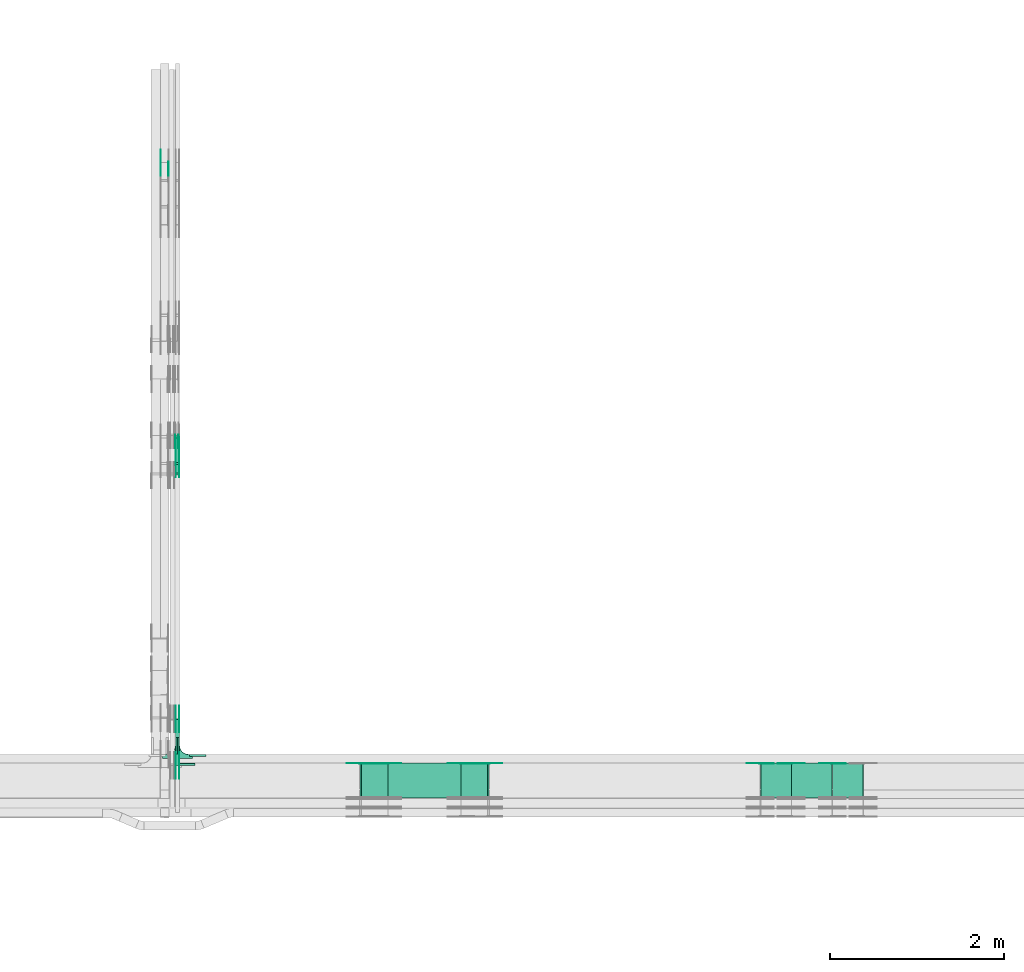
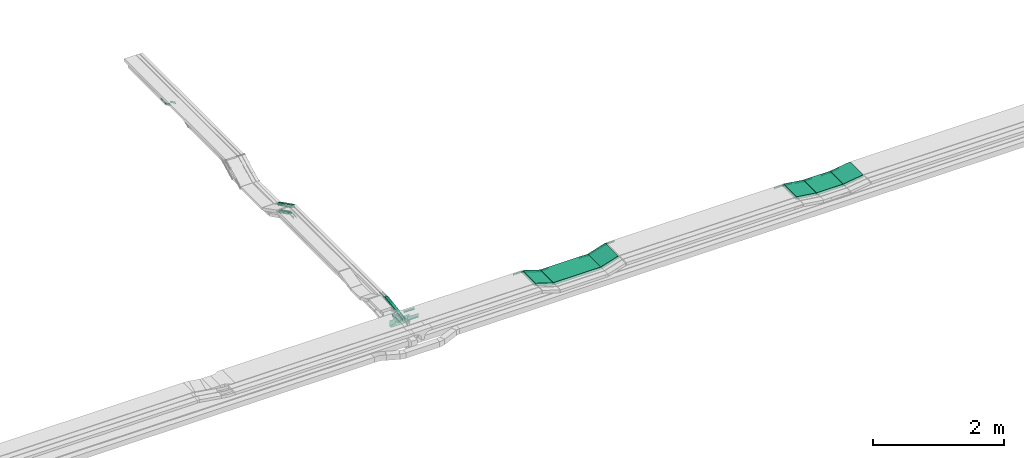
# One storey, part 19 of 28: 38 flow fittings, 9 flow segments.
"""IFC2X3 building model written with IfcOpenShell, lengths in millimetres."""

import ifcopenshell
import ifcopenshell.guid

model = None  # the IFC model being written
_history = None  # IfcOwnerHistory: only IFC2X3 demands one
_inside = {}  # id of a spatial element -> (the spatial element, [elements in it])
_under = {}  # id of a project, library or spatial element -> (it, [spatial elements below it])
_declared = {}  # id of a project -> (the project, [libraries it declares])
_typed = {}  # id of a type object -> (the type object, [elements of that type])
_made_of = {}  # id of a material, layer set ... -> (it, [elements and type objects made of it])


def new_model(schema):
    """Start an empty IFC model of exactly this schema.

    Asked for "IFC4X3", IfcOpenShell would pick the latest addendum, in which some entities
    have other attributes; the version numbers below select the first issue.
    IFC2X3 requires an IfcOwnerHistory on every rooted entity: one is made here for all.
    """
    global model, _history
    if schema == "IFC4X3":
        model = ifcopenshell.file(schema_version=(4, 3, 0, 0))
    else:
        model = ifcopenshell.file(schema=schema)
    _inside.clear()
    _under.clear()
    _declared.clear()
    _typed.clear()
    _made_of.clear()
    _history = None
    if model.schema == "IFC2X3":
        org = make("IfcOrganization", Name="unknown")
        user = make(
            "IfcPersonAndOrganization",
            ThePerson=make("IfcPerson", FamilyName="unknown"),
            TheOrganization=org,
        )
        app = make(
            "IfcApplication",
            ApplicationDeveloper=org,
            Version="unknown",
            ApplicationFullName="unknown",
            ApplicationIdentifier="unknown",
        )
        _history = make(
            "IfcOwnerHistory",
            OwningUser=user,
            OwningApplication=app,
            ChangeAction="ADDED",
            CreationDate=0,
        )
    return model


def make(cls, **values):
    """One entity of the class cls with the attributes given. An attribute that is None is left unset."""
    return model.create_entity(
        cls, **{name: value for name, value in values.items() if value is not None}
    )


def entity(cls, *values):
    """Any entity or typed value of the class cls, its attributes in the order of the schema. None: left unset."""
    e = model.create_entity(cls)
    for i, value in enumerate(values):
        if value is not None:
            e[i] = value
    return e


def rooted(cls, **values):
    """An entity with a GlobalId (a new one), such as an element, a storey or a relation."""
    return make(cls, GlobalId=ifcopenshell.guid.new(), OwnerHistory=_history, **values)


def si_unit(unit_type, name, prefix=None):
    """IfcSIUnit, for example si_unit("LENGTHUNIT", "METRE", prefix="MILLI")."""
    return make("IfcSIUnit", UnitType=unit_type, Prefix=prefix, Name=name)


def converted_unit(unit_type, name, factor, base, dimensions=None, offset=None):
    """IfcConversionBasedUnit, such as the inch: factor (a typed value) times the base unit."""
    return make(
        "IfcConversionBasedUnit"
        if offset is None
        else "IfcConversionBasedUnitWithOffset",
        ConversionOffset=offset,
        Dimensions=None
        if dimensions is None
        else entity("IfcDimensionalExponents", *dimensions),
        UnitType=unit_type,
        Name=name,
        ConversionFactor=make(
            "IfcMeasureWithUnit", ValueComponent=factor, UnitComponent=base
        ),
    )


def derived_unit(unit_type, elements):
    """IfcDerivedUnit: a product of units, each with its exponent."""
    return make(
        "IfcDerivedUnit",
        Elements=[
            make("IfcDerivedUnitElement", Unit=unit, Exponent=power)
            for unit, power in elements
        ],
        UnitType=unit_type,
    )


def assignment(units):
    """IfcUnitAssignment: the units of a project."""
    return None if units is None else make("IfcUnitAssignment", Units=units)


def point(xyz):
    """IfcCartesianPoint."""
    return None if xyz is None else make("IfcCartesianPoint", Coordinates=xyz)


def direction(xyz):
    """IfcDirection."""
    return None if xyz is None else make("IfcDirection", DirectionRatios=xyz)


def frame(location, z_axis=None, x_axis=None):
    """IfcAxis2Placement3D, a coordinate frame: its origin and axes. An axis left out is left unset."""
    return make(
        "IfcAxis2Placement3D",
        Location=point(location),
        Axis=direction(z_axis),
        RefDirection=direction(x_axis),
    )


def frame_2d(location, x_axis=None):
    """IfcAxis2Placement2D, a coordinate frame in the plane: its origin and x axis."""
    return make(
        "IfcAxis2Placement2D", Location=point(location), RefDirection=direction(x_axis)
    )


def origin():
    """The frame at (0, 0, 0) with its axes left unset."""
    return frame((0.0, 0.0, 0.0))


def place(relative_to, where):
    """IfcLocalPlacement: puts the frame where relative to a parent placement (None: the world)."""
    return make(
        "IfcLocalPlacement", PlacementRelTo=relative_to, RelativePlacement=where
    )


def context(
    kind, dimensions, precision=None, world=None, true_north=None, identifier=None
):
    """IfcGeometricRepresentationContext, for example the 3D "Model" context."""
    return make(
        "IfcGeometricRepresentationContext",
        ContextIdentifier=identifier,
        ContextType=kind,
        CoordinateSpaceDimension=dimensions,
        Precision=precision,
        WorldCoordinateSystem=world,
        TrueNorth=true_north,
    )


def subcontext(parent, identifier, kind, view, scale=None):
    """IfcGeometricRepresentationSubContext, for example "Body" below "Model"."""
    return make(
        "IfcGeometricRepresentationSubContext",
        ContextIdentifier=identifier,
        ContextType=kind,
        ParentContext=parent,
        TargetScale=scale,
        TargetView=view,
    )


def project(units=None, contexts=None):
    """IfcProject with its units and contexts."""
    return rooted(
        "IfcProject",
        Name="project",
        RepresentationContexts=contexts,
        UnitsInContext=assignment(units),
    )


def spatial(cls, under=None, at=None, **own):
    """A site, building, storey or space (cls), placed at a placement, below another one or the project."""
    s = rooted(cls, ObjectPlacement=at, **own)
    if under is not None:
        _under.setdefault(under.id(), (under, []))[1].append(s)
    return s


def polyline(points):
    """IfcPolyline through the points."""
    return make("IfcPolyline", Points=[point(p) for p in points])


def circle_curve(where, radius):
    """IfcCircle in the frame where."""
    return make("IfcCircle", Position=where, Radius=radius)


def parameter(value):
    """IfcParameterValue: where a trimmed curve begins or ends, as a parameter of its basis curve."""
    return model.create_entity("IfcParameterValue", value)


def trimmed(basis, trim1, trim2, sense, master):
    """IfcTrimmedCurve: the piece of a basis curve between two trims."""
    return make(
        "IfcTrimmedCurve",
        BasisCurve=basis,
        Trim1=trim1,
        Trim2=trim2,
        SenseAgreement=sense,
        MasterRepresentation=master,
    )


def segment(curve, same_sense, transition):
    """IfcCompositeCurveSegment."""
    return make(
        "IfcCompositeCurveSegment",
        Transition=transition,
        SameSense=same_sense,
        ParentCurve=curve,
    )


def composite_curve(segments, self_intersect=None):
    """IfcCompositeCurve: segments joined end to end."""
    return make("IfcCompositeCurve", Segments=segments, SelfIntersect=self_intersect)


def profile(cls, at=None, kind="AREA", **sizes):
    """A parametric profile (cls). Its sizes go by their IFC names, for example OverallWidth=200.0."""
    return make(cls, ProfileType=kind, Position=at, **sizes)


def rectangle(**sizes):
    """IfcRectangleProfileDef."""
    return profile("IfcRectangleProfileDef", **sizes)


def outline(outer, holes=None, kind="AREA"):
    """IfcArbitraryClosedProfileDef: a profile drawn as a closed curve; with holes, ...WithVoids."""
    if holes is None:
        return make("IfcArbitraryClosedProfileDef", ProfileType=kind, OuterCurve=outer)
    return make(
        "IfcArbitraryProfileDefWithVoids",
        ProfileType=kind,
        OuterCurve=outer,
        InnerCurves=holes,
    )


def extrude(swept, where, along, depth):
    """IfcExtrudedAreaSolid: the profile swept, set in the frame where, extruded along a direction by depth."""
    return make(
        "IfcExtrudedAreaSolid",
        SweptArea=swept,
        Position=where,
        ExtrudedDirection=direction(along),
        Depth=depth,
    )


def faces_of(points, faces, orient=None, outer=None):
    """IfcFace entities. A face is a list of loops; a loop is a list of indices into points, from 0.

    orient and outer hold one flag for each loop. By default every Orientation is true, the
    first loop of a face is its IfcFaceOuterBound and the others are IfcFaceBound.
    """
    made = []
    for i, loops in enumerate(faces):
        bounds = []
        for j, loop in enumerate(loops):
            is_outer = j == 0 if outer is None else outer[i][j]
            bounds.append(
                make(
                    "IfcFaceOuterBound" if is_outer else "IfcFaceBound",
                    Bound=make("IfcPolyLoop", Polygon=[points[k] for k in loop]),
                    Orientation=True if orient is None else orient[i][j],
                )
            )
        made.append(make("IfcFace", Bounds=bounds))
    return made


def faceted_brep(points, faces, orient=None, outer=None, voids=None):
    """IfcFacetedBrep: a solid bounded by flat faces; with voids (closed shells), ...WithVoids."""
    shared = [point(p) for p in points]
    hull = make("IfcClosedShell", CfsFaces=faces_of(shared, faces, orient, outer))
    if voids is None:
        return make("IfcFacetedBrep", Outer=hull)
    return make(
        "IfcFacetedBrepWithVoids",
        Outer=hull,
        Voids=[
            make(cls, CfsFaces=faces_of(shared, fs, o, b)) for cls, fs, o, b in voids
        ],
    )


def shape(context_of_items, identifier, shape_type, items):
    """IfcShapeRepresentation: the items that make up one representation, for example the "Body"."""
    return make(
        "IfcShapeRepresentation",
        ContextOfItems=context_of_items,
        RepresentationIdentifier=identifier,
        RepresentationType=shape_type,
        Items=items,
    )


def source(mapping_origin, context_of_items, identifier, shape_type, items):
    """IfcRepresentationMap: a shape defined once, which mapped items show again and again."""
    return make(
        "IfcRepresentationMap",
        MappingOrigin=mapping_origin,
        MappedRepresentation=shape(context_of_items, identifier, shape_type, items),
    )


def transform(
    local_origin,
    x_axis=None,
    y_axis=None,
    z_axis=None,
    scale=None,
    scale2=None,
    scale3=None,
    uniform=True,
):
    """IfcCartesianTransformationOperator3D, or its non-uniform kind. x_axis, y_axis, z_axis: its Axis1, 2, 3."""
    if uniform:
        return make(
            "IfcCartesianTransformationOperator3D",
            Axis1=direction(x_axis),
            Axis2=direction(y_axis),
            LocalOrigin=point(local_origin),
            Scale=scale,
            Axis3=direction(z_axis),
        )
    return make(
        "IfcCartesianTransformationOperator3DnonUniform",
        Axis1=direction(x_axis),
        Axis2=direction(y_axis),
        LocalOrigin=point(local_origin),
        Scale=scale,
        Axis3=direction(z_axis),
        Scale2=scale2,
        Scale3=scale3,
    )


def mapped(mapping_source, mapping_target):
    """IfcMappedItem: shows the shape of a source again, moved by a transform."""
    return make(
        "IfcMappedItem", MappingSource=mapping_source, MappingTarget=mapping_target
    )


def material(Name=None, Category=None):
    """IfcMaterial."""
    return make("IfcMaterial", Name=Name, Category=Category)


def made_of(thing, what):
    """Note that an element or type object is made of a material, layer set ...; save() writes the relation."""
    if what is not None:
        _made_of.setdefault(what.id(), (what, []))[1].append(thing)
    return thing


def type_object(cls, material=None, **own):
    """A type object (cls), such as IfcWallType, which elements share."""
    return made_of(rooted(cls, **own), material)


def type_shapes(of_type, sources):
    """Give a type object the sources (RepresentationMaps) that its elements show as mapped items."""
    of_type.RepresentationMaps = sources


def element(
    cls,
    number,
    at=None,
    inside=None,
    cuts=None,
    type_object=None,
    material=None,
    context=None,
    identifier="Body",
    shape_type=None,
    held_by="IfcProductDefinitionShape",
    body=None,
    shapes=None,
    **own,
):
    """One element of the class cls, such as IfcWall. Its Tag is "e" and its number.

    at: its placement. inside: the storey or other place that contains it. cuts: it is an
    opening in that element (IfcRelVoidsElement). A single representation is given by context,
    identifier, shape_type and body (its items); several are given by shapes. held_by: the class
    of the entity that holds the representations. save() writes the other relations.
    """
    e = rooted(cls, Tag="e%d" % number, ObjectPlacement=at, **own)
    if body is not None:
        shapes = [shape(context, identifier, shape_type, body)]
    if shapes is not None:
        e.Representation = make(held_by, Representations=shapes)
    if inside is not None:
        _inside.setdefault(inside.id(), (inside, []))[1].append(e)
    if cuts is not None:
        rooted(
            "IfcRelVoidsElement", RelatingBuildingElement=cuts, RelatedOpeningElement=e
        )
    if type_object is not None:
        _typed.setdefault(type_object.id(), (type_object, []))[1].append(e)
    return made_of(e, material)


def aggregate(whole, parts):
    """IfcRelAggregates: a whole, such as a stair, and the parts it consists of."""
    return rooted("IfcRelAggregates", RelatingObject=whole, RelatedObjects=parts)


def save(model, path):
    """Write the relations noted so far, then the file.

    IfcRelAggregates (storeys below a building ...), IfcRelContainedInSpatialStructure (elements
    in a storey), IfcRelDefinesByType, IfcRelAssociatesMaterial and IfcRelDeclares: one each for
    every whole, place, type object, material and project.
    """
    for whole, parts in _under.values():
        aggregate(whole, parts)
    for where, things in _inside.values():
        rooted(
            "IfcRelContainedInSpatialStructure",
            RelatedElements=things,
            RelatingStructure=where,
        )
    for kind, things in _typed.values():
        rooted("IfcRelDefinesByType", RelatedObjects=things, RelatingType=kind)
    for what, things in _made_of.values():
        rooted("IfcRelAssociatesMaterial", RelatedObjects=things, RelatingMaterial=what)
    for by, libraries in _declared.values():
        rooted("IfcRelDeclares", RelatingContext=by, RelatedDefinitions=libraries)
    model.write(path)


model = new_model("IFC2X3")

# Units and contexts
model_context = context("Model", 3, precision=0.01, world=origin(), true_north=direction((6.12303176911189e-17, 1.0)))
body_context = subcontext(model_context, "Body", "Model", "MODEL_VIEW")
ifc_project = project(units=[si_unit("LENGTHUNIT", "METRE", prefix="MILLI"), si_unit("AREAUNIT", "SQUARE_METRE"), si_unit("VOLUMEUNIT", "CUBIC_METRE"), converted_unit("PLANEANGLEUNIT", "DEGREE", entity("IfcRatioMeasure", 0.0174532925199433), si_unit("PLANEANGLEUNIT", "RADIAN"), dimensions=[0, 0, 0, 0, 0, 0, 0]), si_unit("MASSUNIT", "GRAM", prefix="KILO"), derived_unit("MASSDENSITYUNIT", [(si_unit("MASSUNIT", "GRAM", prefix="KILO"), 1), (si_unit("LENGTHUNIT", "METRE"), -3)]), derived_unit("MOMENTOFINERTIAUNIT", [(si_unit("LENGTHUNIT", "METRE"), 4)]), si_unit("TIMEUNIT", "SECOND"), si_unit("FREQUENCYUNIT", "HERTZ"), si_unit("THERMODYNAMICTEMPERATUREUNIT", "DEGREE_CELSIUS"), derived_unit("THERMALTRANSMITTANCEUNIT", [(si_unit("MASSUNIT", "GRAM", prefix="KILO"), 1), (si_unit("THERMODYNAMICTEMPERATUREUNIT", "KELVIN"), -1), (si_unit("TIMEUNIT", "SECOND"), -3)]), derived_unit("VOLUMETRICFLOWRATEUNIT", [(si_unit("LENGTHUNIT", "METRE"), 3), (si_unit("TIMEUNIT", "SECOND"), -1)]), derived_unit("MASSFLOWRATEUNIT", [(si_unit("MASSUNIT", "GRAM", prefix="KILO"), 1), (si_unit("TIMEUNIT", "SECOND"), -1)]), derived_unit("ROTATIONALFREQUENCYUNIT", [(si_unit("TIMEUNIT", "SECOND"), -1)]), si_unit("ELECTRICCURRENTUNIT", "AMPERE"), si_unit("ELECTRICVOLTAGEUNIT", "VOLT"), si_unit("POWERUNIT", "WATT"), si_unit("FORCEUNIT", "NEWTON", prefix="KILO"), si_unit("ILLUMINANCEUNIT", "LUX"), si_unit("LUMINOUSFLUXUNIT", "LUMEN"), si_unit("LUMINOUSINTENSITYUNIT", "CANDELA"), derived_unit("USERDEFINED", [(si_unit("MASSUNIT", "GRAM", prefix="KILO"), -1), (si_unit("LENGTHUNIT", "METRE"), -2), (si_unit("TIMEUNIT", "SECOND"), 3), (si_unit("LUMINOUSFLUXUNIT", "LUMEN"), 1)]), derived_unit("LINEARVELOCITYUNIT", [(si_unit("LENGTHUNIT", "METRE"), 1), (si_unit("TIMEUNIT", "SECOND"), -1)]), si_unit("PRESSUREUNIT", "PASCAL"), derived_unit("USERDEFINED", [(si_unit("LENGTHUNIT", "METRE"), -2), (si_unit("MASSUNIT", "GRAM", prefix="KILO"), 1), (si_unit("TIMEUNIT", "SECOND"), -2)]), derived_unit("LINEARFORCEUNIT", [(si_unit("MASSUNIT", "GRAM", prefix="KILO"), 1), (si_unit("LENGTHUNIT", "METRE"), 1), (si_unit("TIMEUNIT", "SECOND"), -2), (si_unit("LENGTHUNIT", "METRE"), -1)]), derived_unit("PLANARFORCEUNIT", [(si_unit("MASSUNIT", "GRAM", prefix="KILO"), 1), (si_unit("LENGTHUNIT", "METRE"), 1), (si_unit("TIMEUNIT", "SECOND"), -2), (si_unit("LENGTHUNIT", "METRE"), -2)])], contexts=[model_context])

# Site, building, storey
site_placement = place(None, frame((0.0, -0.00077364408347762, 0.0)))
site = spatial("IfcSite", under=ifc_project, at=site_placement, CompositionType="ELEMENT")
building_placement = place(site_placement, origin())
building = spatial("IfcBuilding", under=site, at=building_placement, CompositionType="ELEMENT")
storey_placement = place(building_placement, origin())
storey = spatial("IfcBuildingStorey", under=building, at=storey_placement, CompositionType="ELEMENT", Elevation=0.0)

# Flow segments
cable_carrier_segment_type = type_object("IfcCableCarrierSegmentType", PredefinedType="CABLETRAYSEGMENT")
flow_segment_1_placement = place(storey_placement, frame((47019.820904201, 8891.69675428226, 2720.74533721719)))
element("IfcFlowSegment", 1, at=flow_segment_1_placement, inside=storey, type_object=cable_carrier_segment_type, context=body_context, shape_type="SweptSolid", body=[
    extrude(rectangle(XDim=50.0000000000005, YDim=533.151523501238, at=frame_2d((0.0, 0.0), x_axis=(0.0, 1.0))), frame((0.0, 267.335697614662, 64.2546627841224), z_axis=(1.0, 0.0, 0.0), x_axis=(0.0, -0.988943608507252, -0.148292073937398)), (0.0, 0.0, 1.0), 50.000000000006),
])
flow_segment_2_placement = place(storey_placement, frame((49465.9124736058, 8520.00006103514, 2750.0)))
element("IfcFlowSegment", 2, at=flow_segment_2_placement, inside=storey, type_object=cable_carrier_segment_type, context=body_context, shape_type="SweptSolid", body=[
    extrude(rectangle(XDim=834.526531103356, YDim=400.0, at=frame_2d((4.34852154285181e-12, 0.0), x_axis=(1.0, 0.0))), frame((417.263265551682, 200.0, 0.0), z_axis=(0.0, 0.0, 1.0), x_axis=(-1.0, 0.0, 0.0)), (0.0, 0.0, 1.0), 49.9999999999995),
])
flow_segment_3_placement = place(storey_placement, frame((47019.8209042011, 12350.3050523626, 2456.22912852374)))
element("IfcFlowSegment", 3, at=flow_segment_3_placement, inside=storey, type_object=cable_carrier_segment_type, context=body_context, shape_type="SweptSolid", body=[
    extrude(rectangle(XDim=50.0000000000007, YDim=317.472558766534, at=frame_2d((9.66338120633736e-13, 4.86721773995669e-13), x_axis=(0.0, 1.0))), frame((0.0, 153.000824609218, 93.7708714767046), z_axis=(1.0, 0.0, 0.0), x_axis=(0.0, 0.892980854208935, -0.450094650064052)), (0.0, 0.0, 1.0), 50.000000000006),
])
flow_segment_4_placement = place(storey_placement, frame((47012.1849606245, 12227.7977453006, 2581.18180348874)))
element("IfcFlowSegment", 4, at=flow_segment_4_placement, inside=storey, type_object=cable_carrier_segment_type, context=body_context, shape_type="SweptSolid", body=[
    extrude(rectangle(XDim=50.0000000000015, YDim=484.209321850101, at=frame_2d((-8.38440428196918e-13, -7.37188088351104e-13), x_axis=(0.0, 1.0))), frame((0.0, 227.447193171986, 131.294533994177), z_axis=(1.0, 0.0, 0.0), x_axis=(0.0, 0.892980854206702, -0.450094650068481)), (0.0, 0.0, 1.0), 50.000000000006),
])
flow_segment_5_placement = place(storey_placement, frame((54101.1292071318, 8520.00006103515, 2800.0)))
element("IfcFlowSegment", 5, at=flow_segment_5_placement, inside=storey, type_object=cable_carrier_segment_type, context=body_context, shape_type="SweptSolid", body=[
    extrude(rectangle(XDim=466.843004853572, YDim=400.0, at=frame_2d((4.33431068813661e-12, 0.0), x_axis=(1.0, 0.0))), frame((233.421502426782, 200.0, 0.0), z_axis=(0.0, 0.0, 1.0), x_axis=(-1.0, 0.0, 0.0)), (0.0, 0.0, 1.0), 49.9999999999995),
])
flow_segment_6_placement = place(storey_placement, frame((54570.5191724579, 8520.00006103515, 2800.66469738891)))
element("IfcFlowSegment", 6, at=flow_segment_6_placement, inside=storey, type_object=cable_carrier_segment_type, context=body_context, shape_type="SweptSolid", body=[
    extrude(rectangle(XDim=50.0000000000001, YDim=353.209071623864, at=frame_2d((-8.56914539326681e-12, -1.20614629395277e-12), x_axis=(0.0, 1.0))), frame((178.365160133476, 0.0, 49.3353026111005), z_axis=(0.0, 1.0, 0.0), x_axis=(-0.990268068741569, 0.0, -0.139173100960075)), (0.0, 0.0, 1.0), 400.0),
])
flow_segment_7_placement = place(storey_placement, frame((53741.8519263918, 8520.00006103515, 2800.6646973889)))
element("IfcFlowSegment", 7, at=flow_segment_7_placement, inside=storey, type_object=cable_carrier_segment_type, context=body_context, shape_type="SweptSolid", body=[
    extrude(rectangle(XDim=49.9999999999989, YDim=353.209071624417, at=frame_2d((2.8421709430404e-14, 2.70006239588838e-13), x_axis=(0.0, 1.0))), frame((178.365160133745, 0.0, 49.3353026111179), z_axis=(0.0, 1.0, 0.0), x_axis=(0.990268068741587, 0.0, -0.139173100959945)), (0.0, 0.0, 1.0), 399.999999999999),
])
flow_segment_8_placement = place(storey_placement, frame((50303.5978979932, 8520.00006103514, 2752.8115162139)))
element("IfcFlowSegment", 8, at=flow_segment_8_placement, inside=storey, type_object=cable_carrier_segment_type, context=body_context, shape_type="SweptSolid", body=[
    extrude(rectangle(XDim=49.9999999999976, YDim=320.899186882727, at=frame_2d((-8.5265128291212e-14, 2.57571741713036e-13), x_axis=(0.0, 1.0))), frame((160.52476054269, 0.0, 72.188483786116), z_axis=(0.0, 1.0, 0.0), x_axis=(-0.95351533837897, 0.0, -0.30134448638732)), (0.0, 0.0, 1.0), 400.0),
])
flow_segment_9_placement = place(storey_placement, frame((49141.7040592364, 8520.00006103514, 2752.81151621389)))
element("IfcFlowSegment", 9, at=flow_segment_9_placement, inside=storey, type_object=cable_carrier_segment_type, context=body_context, shape_type="SweptSolid", body=[
    extrude(rectangle(XDim=50.0000000000033, YDim=320.89918688297, at=frame_2d((4.06430444854777e-12, -1.56674673235102e-12), x_axis=(0.0, 1.0))), frame((160.52476054282, 0.0, 72.1884837861258), z_axis=(0.0, 1.0, 0.0), x_axis=(0.953515338379031, 0.0, -0.301344486387127)), (0.0, 0.0, 1.0), 400.0),
])

# Flow fittings
ifc_material_1 = material(Name="G")
cable_carrier_fitting_type_1 = type_object("IfcCableCarrierFittingType", PredefinedType="NOTDEFINED", material=ifc_material_1)
shared_shape_1 = source(origin(), body_context, "Body", "SweptSolid", [
    extrude(outline(composite_curve([segment(trimmed(circle_curve(frame_2d((-44.5901162790698, 0.0), x_axis=(1.0, 0.0)), 12.5), [parameter(90.0000000000007)], [parameter(270.0)], True, "PARAMETER"), True, "CONTINUOUS"), segment(polyline([(-44.5901162790697, -12.5), (-33.0901162790698, -12.5)]), True, "CONTINUOUS"), segment(polyline([(-33.0901162790698, -12.5), (-31.2296511627907, -14.5)]), True, "CONTINUOUS"), segment(polyline([(-31.2296511627907, -14.5), (108.90988372093, -14.5)]), True, "CONTINUOUS"), segment(polyline([(108.90988372093, -14.5), (108.90988372093, 14.5)]), True, "CONTINUOUS"), segment(polyline([(108.90988372093, 14.5), (-31.2296511627907, 14.5)]), True, "CONTINUOUS"), segment(polyline([(-31.2296511627907, 14.5), (-33.0901162790698, 12.5)]), True, "CONTINUOUS"), segment(polyline([(-33.0901162790698, 12.5), (-44.5901162790699, 12.5)]), True, "CONTINUOUS")], self_intersect=False)), frame((44.5901162790698, 0.0, 0.0), z_axis=(0.0, 0.0, -1.0), x_axis=(1.0, 0.0, 0.0)), (0.0, 0.0, -1.0), 2.0),
])
type_shapes(cable_carrier_fitting_type_1, [shared_shape_1])
for number, where, z_axis, x_axis in (
    (10, (47065.2809042112, 12354.5070319829, 2625.0), (1.0, 0.0, 0.0), (0.0, -1.0, 0.0)),
    (11, (47024.6621308488, 9425.7880733449, 2825.0), (-1.0, 0.0, 0.0), (0.0, 1.0, 0.0)),
    (12, (47024.6621308488, 8892.27683044894, 2745.0), (-1.0, 0.0, 0.0), (0.0, -1.0, 0.0)),
    (13, (54571.0, 8915.46006104531, 2825.0), (0.0, 1.0, 0.0), (-1.0, 0.0, 0.0)),
    (14, (50622.3328434659, 8915.4600610453, 2875.0), (0.0, 1.0, 0.0), (1.0, 0.0, 0.0)),
    (15, (50305.9124736058, 8915.4600610453, 2775.0), (0.0, 1.0, 0.0), (-1.0, 0.0, 0.0)),
):
    element("IfcFlowFitting", number, at=place(storey_placement, frame(where, z_axis=z_axis, x_axis=x_axis)), inside=storey, type_object=cable_carrier_fitting_type_1, material=ifc_material_1, context=body_context, shape_type="MappedRepresentation", body=[
        mapped(shared_shape_1, transform((0.0, 0.0, 0.0), scale=1.0)),
    ])
cable_carrier_fitting_type_2 = type_object("IfcCableCarrierFittingType", PredefinedType="NOTDEFINED", material=ifc_material_1)
shared_shape_2 = source(origin(), body_context, "Body", "SweptSolid", [
    extrude(outline(composite_curve([segment(trimmed(circle_curve(frame_2d((-44.5901162790697, 0.0), x_axis=(1.0, 0.0)), 12.5), [parameter(90.0000000000007)], [parameter(270.0)], True, "PARAMETER"), True, "CONTINUOUS"), segment(polyline([(-44.5901162790697, -12.5), (-33.0901162790697, -12.5)]), True, "CONTINUOUS"), segment(polyline([(-33.0901162790697, -12.5), (-31.2296511627907, -14.5)]), True, "CONTINUOUS"), segment(polyline([(-31.2296511627907, -14.5), (108.90988372093, -14.5)]), True, "CONTINUOUS"), segment(polyline([(108.90988372093, -14.5), (108.90988372093, 14.5)]), True, "CONTINUOUS"), segment(polyline([(108.90988372093, 14.5), (-31.2296511627907, 14.5)]), True, "CONTINUOUS"), segment(polyline([(-31.2296511627907, 14.5), (-33.0901162790698, 12.5)]), True, "CONTINUOUS"), segment(polyline([(-33.0901162790698, 12.5), (-44.5901162790699, 12.5)]), True, "CONTINUOUS")], self_intersect=False)), frame((44.5901162790697, 0.0, 0.0)), (0.0, 0.0, 1.0), 2.0),
])
type_shapes(cable_carrier_fitting_type_2, [shared_shape_2])
for number, where, z_axis, x_axis in (
    (16, (47024.3609041909, 12354.5070319829, 2625.0), (-1.0, 0.0, 0.0), (0.0, -1.0, 0.0)),
    (17, (47065.5821308691, 9425.7880733449, 2825.0), (1.0, 0.0, 0.0), (0.0, 1.0, 0.0)),
    (18, (47065.5821308691, 8892.27683044894, 2745.0), (1.0, 0.0, 0.0), (0.0, -1.0, 0.0)),
    (19, (46852.3097248873, 15815.1043788559, 2625.0), (-1.0, 0.0, 0.0), (0.0, 1.0, 0.0)),
    (20, (54098.1013295855, 8915.46006104531, 2825.0), (0.0, 1.0, 0.0), (1.0, 0.0, 0.0)),
    (21, (53742.3328434656, 8915.46006104531, 2875.0), (0.0, 1.0, 0.0), (-1.0, 0.0, 0.0)),
    (22, (49460.4390047093, 8915.4600610453, 2775.0), (0.0, 1.0, 0.0), (1.0, 0.0, 0.0)),
    (23, (49144.018634849, 8915.4600610453, 2875.0), (0.0, 1.0, 0.0), (-1.0, 0.0, 0.0)),
):
    element("IfcFlowFitting", number, at=place(storey_placement, frame(where, z_axis=z_axis, x_axis=x_axis)), inside=storey, type_object=cable_carrier_fitting_type_2, material=ifc_material_1, context=body_context, shape_type="MappedRepresentation", body=[
        mapped(shared_shape_2, transform((0.0, 0.0, 0.0), scale=1.0)),
    ])
cable_carrier_fitting_type_3 = type_object("IfcCableCarrierFittingType", PredefinedType="NOTDEFINED", material=ifc_material_1)
shared_shape_3 = source(origin(), body_context, "Body", "SweptSolid", [
    extrude(outline(composite_curve([segment(trimmed(circle_curve(frame_2d((-44.5901162790698, 0.0), x_axis=(1.0, 0.0)), 12.5), [parameter(90.0000000000007)], [parameter(270.0)], True, "PARAMETER"), True, "CONTINUOUS"), segment(polyline([(-44.5901162790697, -12.5), (-33.0901162790698, -12.5)]), True, "CONTINUOUS"), segment(polyline([(-33.0901162790698, -12.5), (-31.2296511627907, -14.5)]), True, "CONTINUOUS"), segment(polyline([(-31.2296511627907, -14.5), (108.90988372093, -14.5)]), True, "CONTINUOUS"), segment(polyline([(108.90988372093, -14.5), (108.90988372093, 14.5)]), True, "CONTINUOUS"), segment(polyline([(108.90988372093, 14.5), (-31.2296511627907, 14.5)]), True, "CONTINUOUS"), segment(polyline([(-31.2296511627907, 14.5), (-33.0901162790698, 12.5)]), True, "CONTINUOUS"), segment(polyline([(-33.0901162790698, 12.5), (-44.5901162790699, 12.5)]), True, "CONTINUOUS")], self_intersect=False)), frame((44.5901162790698, 0.0, 0.0), z_axis=(0.0, 0.0, -1.0), x_axis=(1.0, 0.0, 0.0)), (0.0, 0.0, -1.0), 2.0),
])
type_shapes(cable_carrier_fitting_type_3, [shared_shape_3])
for number, where, z_axis, x_axis in (
    (24, (47026.3609041909, 12652.1047219608, 2475.0), (-1.0, 0.0, 0.0), (0.0, -0.892980854206722, 0.450094650068442)),
    (25, (47026.3609041909, 12354.5070319829, 2625.0), (-1.0, 0.0, 0.0), (0.0, 0.892980854206722, -0.450094650068442)),
    (26, (47018.7249606144, 12678.4901520242, 2599.95267496582), (-1.0, 0.0, 0.0), (0.0, -0.892980854206714, 0.450094650068457)),
    (27, (47063.5821308691, 9425.78807334492, 2825.0), (1.0, 0.0, 0.0), (0.0, -0.988943608506525, -0.148292073942246)),
    (28, (47063.5821308691, 8892.27683044891, 2745.0), (1.0, 0.0, 0.0), (0.0, 0.988943608506523, 0.148292073942261)),
    (29, (46854.3097248873, 15815.104378856, 2625.0), (-1.0, 0.0, 0.0), (0.0, -0.898794046299012, 0.438371146789395)),
    (30, (54098.1013295855, 8913.46006104531, 2825.0), (0.0, 1.0, 0.0), (-0.990268068741579, 0.0, 0.139173100960007)),
    (31, (53742.3328434656, 8913.46006104531, 2875.0), (0.0, 1.0, 0.0), (0.990268068741587, 0.0, -0.139173100959947)),
    (32, (49460.4390047093, 8913.4600610453, 2775.0), (0.0, 1.0, 0.0), (-0.953515338379008, 0.0, 0.3013444863872)),
    (33, (49144.018634849, 8913.4600610453, 2875.0), (0.0, 1.0, 0.0), (0.953515338379043, 0.0, -0.301344486387091)),
):
    element("IfcFlowFitting", number, at=place(storey_placement, frame(where, z_axis=z_axis, x_axis=x_axis)), inside=storey, type_object=cable_carrier_fitting_type_3, material=ifc_material_1, context=body_context, shape_type="MappedRepresentation", body=[
        mapped(shared_shape_3, transform((0.0, 0.0, 0.0), scale=1.0)),
    ])
cable_carrier_fitting_type_4 = type_object("IfcCableCarrierFittingType", PredefinedType="NOTDEFINED", material=ifc_material_1)
shared_shape_4 = source(origin(), body_context, "Body", "SweptSolid", [
    extrude(outline(composite_curve([segment(trimmed(circle_curve(frame_2d((-44.5901162790697, 0.0), x_axis=(1.0, 0.0)), 12.5), [parameter(90.0000000000007)], [parameter(270.0)], True, "PARAMETER"), True, "CONTINUOUS"), segment(polyline([(-44.5901162790697, -12.5), (-33.0901162790697, -12.5)]), True, "CONTINUOUS"), segment(polyline([(-33.0901162790697, -12.5), (-31.2296511627907, -14.5)]), True, "CONTINUOUS"), segment(polyline([(-31.2296511627907, -14.5), (108.90988372093, -14.5)]), True, "CONTINUOUS"), segment(polyline([(108.90988372093, -14.5), (108.90988372093, 14.5)]), True, "CONTINUOUS"), segment(polyline([(108.90988372093, 14.5), (-31.2296511627907, 14.5)]), True, "CONTINUOUS"), segment(polyline([(-31.2296511627907, 14.5), (-33.0901162790698, 12.5)]), True, "CONTINUOUS"), segment(polyline([(-33.0901162790698, 12.5), (-44.5901162790699, 12.5)]), True, "CONTINUOUS")], self_intersect=False)), frame((44.5901162790697, 0.0, 0.0)), (0.0, 0.0, 1.0), 2.0),
])
type_shapes(cable_carrier_fitting_type_4, [shared_shape_4])
for number, where, z_axis, x_axis in (
    (34, (47063.2809042112, 12652.1047219608, 2475.0), (1.0, 0.0, 0.0), (0.0, -0.892980854206722, 0.450094650068442)),
    (35, (47063.2809042112, 12354.5070319829, 2625.0), (1.0, 0.0, 0.0), (0.0, 0.892980854206722, -0.450094650068442)),
    (36, (47055.6449606347, 12678.4901520242, 2599.95267496582), (1.0, 0.0, 0.0), (0.0, -0.892980854206714, 0.450094650068457)),
    (37, (47026.6621308488, 9425.78807334492, 2825.0), (-1.0, 0.0, 0.0), (0.0, -0.988943608506525, -0.148292073942246)),
    (38, (47026.6621308488, 8892.27683044891, 2745.0), (-1.0, 0.0, 0.0), (0.0, 0.988943608506523, 0.148292073942261)),
    (39, (46941.2297249076, 15815.104378856, 2625.0), (1.0, 0.0, 0.0), (0.0, -0.898794046299012, 0.438371146789395)),
    (40, (54571.0, 8913.4600610453, 2825.0), (0.0, 1.0, 0.0), (0.99026806874157, 0.0, 0.139173100960071)),
    (41, (50622.3328434659, 8913.4600610453, 2875.0), (0.0, 1.0, 0.0), (-0.953515338378991, 0.0, -0.301344486387255)),
    (42, (50305.9124736058, 8913.4600610453, 2775.0), (0.0, 1.0, 0.0), (0.953515338378973, 0.0, 0.301344486387313)),
):
    element("IfcFlowFitting", number, at=place(storey_placement, frame(where, z_axis=z_axis, x_axis=x_axis)), inside=storey, type_object=cable_carrier_fitting_type_4, material=ifc_material_1, context=body_context, shape_type="MappedRepresentation", body=[
        mapped(shared_shape_4, transform((0.0, 0.0, 0.0), scale=1.0)),
    ])
ifc_material_2 = material()
cable_carrier_fitting_type_5 = type_object("IfcCableCarrierFittingType", PredefinedType="NOTDEFINED", material=ifc_material_2)
shared_shape_5 = source(origin(), body_context, "Body", "Brep", [
    faceted_brep([(1.0, 197.500000000001, 50.0), (1.0, 197.500000000001, -47.5000000000011), (1.0, -200.0, -47.5000000000011), (1.0, -200.0, -50.0), (1.0, 200.0, -50.0), (1.0, 200.0, 50.0), (-1.0, 197.500000000001, 50.0), (-1.0, 200.0, 50.0), (-1.0, 200.0, -50.0), (-1.0, -200.0, -50.0), (-1.0, -200.0, -47.5000000000011), (-1.0, 197.500000000001, -47.5000000000011)], [[[0, 1, 2, 3, 4, 5]], [[6, 7, 8, 9, 10, 11]], [[1, 0, 6, 11]], [[2, 1, 11, 10]], [[3, 2, 10, 9]], [[4, 3, 9, 8]], [[5, 4, 8, 7]], [[0, 5, 7, 6]]]),
    faceted_brep([(22.4999999999995, -300.0, 50.0), (22.4999999999995, -350.0, 50.0), (25.0, -350.0, 50.0), (25.0, -300.0, 50.0), (28.4074173710929, -274.118095489749, 50.0), (38.3974596215557, -250.0, 50.0), (54.2893218813448, -229.289321881346, 50.0), (75.0, -213.397459621557, 50.0), (99.1180954897473, -203.407417371094, 50.0), (125.0, -200.0, 50.0), (175.0, -200.0, 50.0), (175.0, -197.5, 50.0), (125.0, -197.500000000001, 50.0), (98.4710478769916, -200.992602805371, 50.0), (73.75, -211.232396112095, 50.0), (52.5215549283788, -227.521554928379, 50.0), (36.2323961120948, -248.75, 50.0), (25.9926028053702, -273.471047876992, 50.0), (-99.1180954897534, -203.407417371094, 50.0), (-75.0, -213.397459621557, 50.0), (-54.2893218813509, -229.289321881346, 50.0), (-38.3974596215619, -250.0, 50.0), (-28.407417371099, -274.118095489749, 50.0), (-25.0, -300.0, 50.0), (-25.0, -350.0, 50.0), (-22.5000000000058, -350.0, 50.0), (-22.5000000000058, -300.0, 50.0), (-25.9926028053763, -273.471047876992, 50.0), (-36.2323961121008, -248.750000000001, 50.0), (-52.5215549283845, -227.52155492838, 50.0), (-73.7500000000056, -211.232396112096, 50.0), (-98.4710478769971, -200.992602805371, 50.0), (-125.0, -197.500000000001, 50.0), (-175.0, -197.500000000001, 50.0), (-175.0, -200.0, 50.0), (-125.0, -200.0, 50.0), (-99.118095489754, -203.407417371094, -50.0), (-114.212641733723, -201.420182658132, -50.0), (-125.0, -200.0, -50.0), (-125.0, -200.0, -52.5), (-112.05904774488, -201.703708685552, -52.5000000000001), (-99.118095489753, -203.407417371099, -52.5000000000001), (-75.0, -213.397459621557, -50.0), (-87.0590477448822, -208.402438496329, -50.0), (-87.0590477448797, -208.40243849633, -52.5000000000001), (-75.0, -213.397459621562, -52.5000000000001), (-64.6446609406813, -221.343390751454, -50.0), (-54.2893218813514, -229.289321881346, -50.0), (-64.6446609406784, -221.343390751456, -52.5000000000001), (-54.2893218813506, -229.289321881351, -52.5000000000001), (-28.4074173710992, -274.118095489748, -50.0), (-33.4024384963323, -262.059047744874, -50.0), (-38.3974596215622, -250.0, -50.0), (-38.3974596215616, -250.0, -52.5000000000001), (-33.4024384963304, -262.059047744879, -52.5000000000001), (-28.4074173710987, -274.118095489753, -52.5000000000001), (-25.0, -300.0, -50.0), (-26.7037086855529, -287.059047744874, -50.0), (-26.420182658065, -289.21264173423, -52.5000000000001), (-25.0, -300.0, -52.5), (-46.3433907514592, -239.644660940674, -50.0), (-46.3433907514565, -239.644660940678, -52.5000000000001), (-25.0, -350.0, -52.5), (25.0, -350.0, -52.5), (22.4999999999995, -350.0, -50.0), (-22.5000000000058, -350.0, -50.0), (-22.5000000000058, -300.0, -50.0), (-25.9926028053761, -273.471047876993, -50.0), (-36.2323961121004, -248.750000000002, -50.0), (-52.5215549283841, -227.52155492838, -50.0), (-73.750000000005, -211.232396112096, -50.0), (-98.4710478769965, -200.992602805371, -50.0), (-125.0, -197.500000000001, -50.0), (25.0, -300.0, -52.5), (25.0, -300.0, -50.0), (28.4074173710927, -274.11809548975, -50.0), (33.4024384963257, -262.059047744877, -50.0), (38.3974596215554, -250.0, -50.0), (28.4074173710929, -274.118095489754, -52.5000000000001), (33.402438496324, -262.059047744881, -52.5000000000001), (38.3974596215557, -250.0, -52.5000000000001), (46.343390751452, -239.644660940677, -50.0), (54.2893218813443, -229.289321881347, -50.0), (46.3433907514499, -239.644660940679, -52.5000000000001), (54.2893218813448, -229.289321881352, -52.5000000000001), (26.4201826582159, -289.212641733042, -50.0), (26.7037086855462, -287.059047744881, -52.5), (75.0, -213.397459621557, -50.0), (87.0590477448741, -208.40243849633, -50.0), (99.1180954897468, -203.407417371094, -50.0), (75.0, -213.397459621562, -52.5000000000001), (87.059047744873, -208.402438496331, -52.5000000000001), (99.1180954897475, -203.407417371099, -52.5000000000001), (112.059047744873, -201.703708685553, -50.0), (125.0, -200.0, -50.0), (114.212641734219, -201.420182658066, -52.5000000000001), (125.0, -200.0, -52.5), (64.6446609406736, -221.343390751456, -50.0), (64.6446609406717, -221.343390751457, -52.5000000000001), (98.471047876991, -200.992602805371, -50.0), (73.7499999999994, -211.232396112096, -50.0), (52.5215549283783, -227.52155492838, -50.0), (125.0, -197.500000000001, -50.0), (36.2323961120945, -248.750000000001, -50.0), (25.99260280537, -273.471047876993, -50.0), (22.4999999999997, -300.0, -50.0), (-175.0, -197.500000000001, -50.0), (175.0, -197.5, -50.0), (-175.0, -150.0, -50.0), (-175.0, -150.0, -52.5), (-175.0, -200.0, -52.5), (175.0, -200.0, -52.5), (175.0, -150.0, -52.5), (175.0, -150.0, -50.0)], [[[0, 1, 2, 3, 4, 5, 6, 7, 8, 9, 10, 11, 12, 13, 14, 15, 16, 17]], [[18, 19, 20, 21, 22, 23, 24, 25, 26, 27, 28, 29, 30, 31, 32, 33, 34, 35]], [[18, 35, 36]], [[35, 37, 36]], [[35, 38, 37]], [[37, 38, 39]], [[37, 39, 40]], [[36, 40, 41]], [[37, 40, 36]], [[19, 18, 42]], [[18, 43, 42]], [[18, 36, 43]], [[36, 41, 43]], [[44, 43, 41]], [[43, 44, 42]], [[44, 45, 42]], [[19, 42, 46]], [[19, 46, 47]], [[47, 20, 19]], [[46, 42, 45]], [[46, 45, 48]], [[48, 49, 47]], [[46, 48, 47]], [[22, 21, 50]], [[21, 51, 50]], [[21, 52, 51]], [[52, 53, 51]], [[54, 51, 53]], [[51, 54, 50]], [[54, 55, 50]], [[23, 22, 56]], [[22, 57, 56]], [[22, 50, 57]], [[50, 55, 57]], [[58, 57, 55]], [[58, 59, 56]], [[57, 58, 56]], [[20, 47, 60]], [[20, 60, 52]], [[52, 21, 20]], [[60, 47, 49]], [[60, 49, 61]], [[60, 61, 52]], [[61, 53, 52]], [[24, 23, 56, 59, 62]], [[25, 24, 62, 63, 2, 1, 64, 65]], [[26, 25, 65, 66]], [[27, 67, 68, 28]], [[28, 68, 69, 29]], [[66, 67, 27, 26]], [[30, 70, 71, 31]], [[31, 71, 72, 32]], [[29, 69, 70, 30]], [[3, 2, 63, 73, 74]], [[5, 4, 75]], [[5, 75, 76]], [[5, 76, 77]], [[75, 78, 76]], [[79, 76, 78]], [[76, 79, 77]], [[79, 80, 77]], [[6, 5, 77]], [[6, 77, 81]], [[6, 81, 82]], [[81, 77, 80]], [[81, 80, 83]], [[83, 84, 82]], [[81, 83, 82]], [[74, 4, 3]], [[4, 74, 85]], [[85, 74, 73]], [[85, 73, 86]], [[85, 86, 75]], [[75, 86, 78]], [[4, 85, 75]], [[8, 7, 87]], [[8, 87, 88]], [[8, 88, 89]], [[87, 90, 88]], [[91, 88, 90]], [[88, 91, 89]], [[91, 92, 89]], [[9, 8, 89]], [[9, 89, 93]], [[9, 93, 94]], [[89, 92, 93]], [[95, 93, 92]], [[95, 96, 94]], [[93, 95, 94]], [[7, 82, 97]], [[6, 82, 7]], [[7, 97, 87]], [[97, 82, 84]], [[97, 84, 98]], [[97, 98, 87]], [[98, 90, 87]], [[13, 99, 100, 14]], [[14, 100, 101, 15]], [[102, 99, 13, 12]], [[16, 103, 104, 17]], [[17, 104, 105, 0]], [[15, 101, 103, 16]], [[1, 0, 105, 64]], [[33, 32, 72, 106]], [[12, 11, 107, 102]], [[34, 33, 106, 108, 109, 110]], [[35, 34, 110, 39, 38]], [[10, 9, 94, 96, 111]], [[10, 111, 112, 113, 107, 11]], [[107, 113, 108, 106, 72, 71, 70, 69, 68, 67, 66, 65, 64, 105, 104, 103, 101, 100, 99, 102]], [[110, 109, 112, 111, 96, 95, 92, 91, 90, 98, 84, 83, 80, 79, 78, 86, 73, 63, 62, 59, 58, 55, 54, 53, 61, 49, 48, 45, 44, 41, 40, 39]], [[108, 113, 112, 109]]]),
])
type_shapes(cable_carrier_fitting_type_5, [shared_shape_5])
flow_fitting_1_placement = place(storey_placement, frame((47044.820904201, 8820.17178445353, 2650.0), z_axis=(0.0, 0.0, 1.0), x_axis=(-1.0, 0.0, 0.0)))
element("IfcFlowFitting", 43, at=flow_fitting_1_placement, inside=storey, type_object=cable_carrier_fitting_type_5, material=ifc_material_2, context=body_context, shape_type="MappedRepresentation", body=[
    mapped(shared_shape_5, transform((0.0, 0.0, 0.0), scale=1.0)),
])
cable_carrier_fitting_type_6 = type_object("IfcCableCarrierFittingType", PredefinedType="NOTDEFINED", material=ifc_material_2)
shared_shape_6 = source(origin(), body_context, "Body", "SweptSolid", [
    extrude(outline(polyline([(-9.16666666666668, -21.5000000000001), (15.8333333333333, -21.5000000000001), (15.8333333333333, -19.0), (-6.66666666666664, -19.0), (-6.66666666666664, 40.5), (-9.16666666666668, 40.5), (-9.16666666666668, -21.5000000000001)])), frame((-95.0, 9.16666666666668, -26.0), z_axis=(1.0, 0.0, 0.0), x_axis=(0.0, 1.0, 0.0)), (0.0, 0.0, 1.0), 190.0),
])
type_shapes(cable_carrier_fitting_type_6, [shared_shape_6])
flow_fitting_2_placement = place(storey_placement, frame((47279.820904201, 9017.67178445353, 2650.0), z_axis=(0.0, 0.0, 1.0), x_axis=(-1.0, 0.0, 0.0)))
element("IfcFlowFitting", 44, at=flow_fitting_2_placement, inside=storey, type_object=cable_carrier_fitting_type_6, material=ifc_material_2, context=body_context, shape_type="MappedRepresentation", body=[
    mapped(shared_shape_6, transform((0.0, 0.0, 0.0), scale=1.0)),
])
cable_carrier_fitting_type_7 = type_object("IfcCableCarrierFittingType", PredefinedType="NOTDEFINED", material=ifc_material_2)
shared_shape_7 = source(origin(), body_context, "Body", "SweptSolid", [
    extrude(outline(polyline([(-9.16666666666668, -21.5000000000001), (15.8333333333333, -21.5000000000001), (15.8333333333333, -19.0), (-6.66666666666664, -19.0), (-6.66666666666664, 40.5), (-9.16666666666668, 40.5), (-9.16666666666668, -21.5000000000001)])), frame((-95.0, 9.16666666666668, -26.0), z_axis=(1.0, 0.0, 0.0), x_axis=(0.0, 1.0, 0.0)), (0.0, 0.0, 1.0), 190.0),
])
type_shapes(cable_carrier_fitting_type_7, [shared_shape_7])
for number, where, z_axis, x_axis in (
    (45, (47022.320904201, 9120.17178445353, 2650.0), (0.0, 0.0, 1.0), (0.0, -1.0, 0.0)),
    (46, (47067.320904201, 9120.17178445353, 2650.0), (0.0, 0.0, 1.0), (0.0, 1.0, 0.0)),
):
    element("IfcFlowFitting", number, at=place(storey_placement, frame(where, z_axis=z_axis, x_axis=x_axis)), inside=storey, type_object=cable_carrier_fitting_type_7, material=ifc_material_2, context=body_context, shape_type="MappedRepresentation", body=[
        mapped(shared_shape_7, transform((0.0, 0.0, 0.0), scale=1.0)),
    ])
cable_carrier_fitting_type_8 = type_object("IfcCableCarrierFittingType", PredefinedType="NOTDEFINED", material=ifc_material_2)
shared_shape_8 = source(origin(), body_context, "Body", "SweptSolid", [
    extrude(outline(polyline([(-9.16666666666668, -11.5000000000001), (15.8333333333333, -11.5000000000001), (15.8333333333333, -9.0), (-6.66666666666664, -9.0), (-6.66666666666664, 20.5), (-9.16666666666668, 20.5), (-9.16666666666668, -11.5000000000001)])), frame((-95.0, 9.16666666666668, -11.0), z_axis=(1.0, 0.0, 0.0), x_axis=(0.0, 1.0, 0.0)), (0.0, 0.0, 1.0), 190.0),
])
type_shapes(cable_carrier_fitting_type_8, [shared_shape_8])
flow_fitting_3_placement = place(storey_placement, frame((47152.1849606245, 8917.50006103515, 2875.0), z_axis=(0.0, 0.0, 1.0), x_axis=(-1.0, 0.0, 0.0)))
element("IfcFlowFitting", 47, at=flow_fitting_3_placement, inside=storey, type_object=cable_carrier_fitting_type_8, material=ifc_material_2, context=body_context, shape_type="MappedRepresentation", body=[
    mapped(shared_shape_8, transform((0.0, 0.0, 0.0), scale=1.0)),
])

save(model, "model.ifc")
